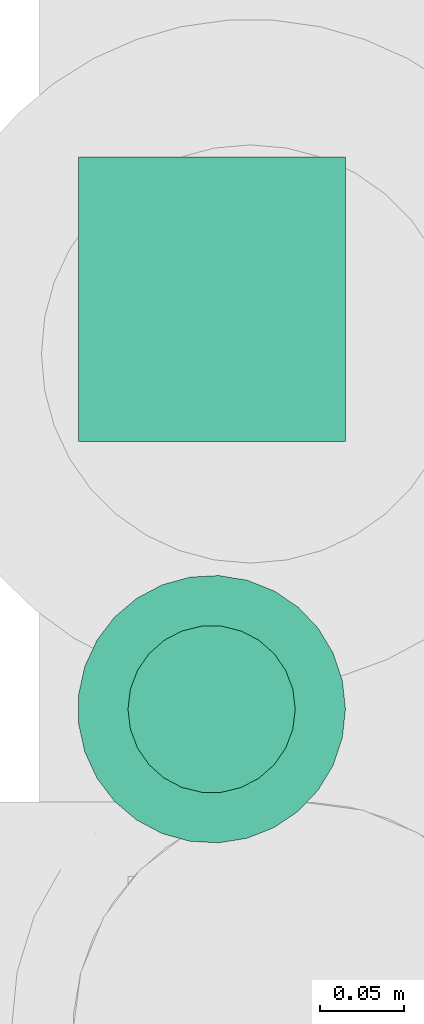
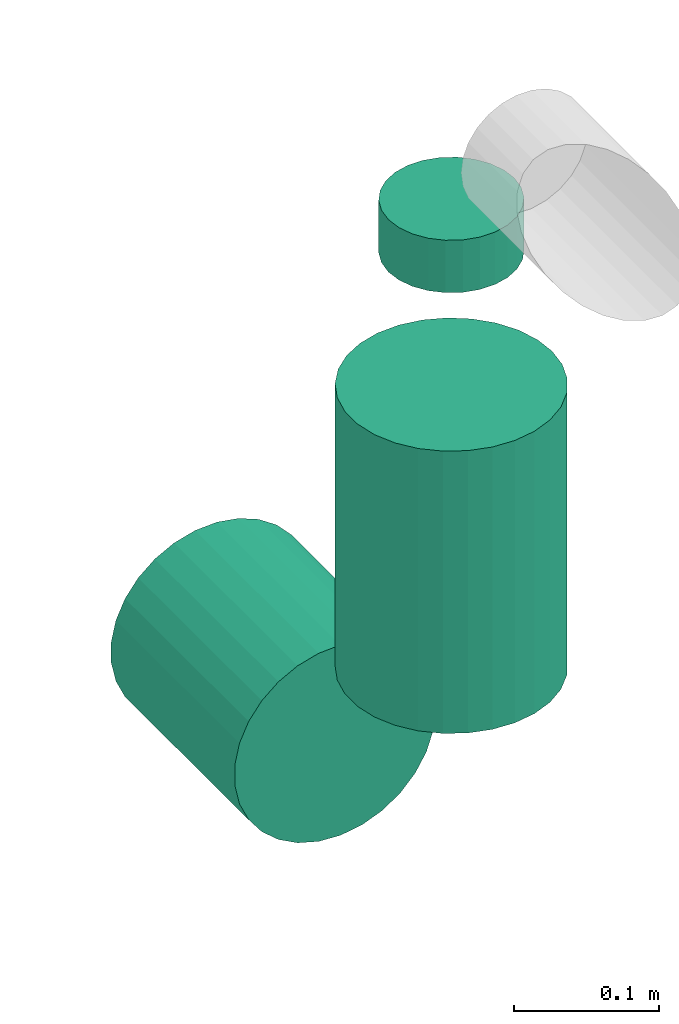
# One storey, part 307 of 337: 3 flow segments.
"""IFC2X3 building model written with IfcOpenShell, lengths in millimetres."""

from ifc_helpers import new_model, entity, si_unit, converted_unit, derived_unit, direction, frame, origin, origin_2d_with_axis, place, context, subcontext, project, spatial, circle, extrude, type_object, element, save


model = new_model("IFC2X3")

# Units and contexts
model_context = context("Model", 3, precision=0.01, world=origin(), true_north=direction((6.12303176911189e-17, 1.0)))
body_context = subcontext(model_context, "Body", "Model", "MODEL_VIEW")
ifc_project = project(units=[si_unit("LENGTHUNIT", "METRE", prefix="MILLI"), si_unit("AREAUNIT", "SQUARE_METRE"), si_unit("VOLUMEUNIT", "CUBIC_METRE"), converted_unit("PLANEANGLEUNIT", "DEGREE", entity("IfcRatioMeasure", 0.0174532925199433), si_unit("PLANEANGLEUNIT", "RADIAN"), dimensions=[0, 0, 0, 0, 0, 0, 0]), si_unit("MASSUNIT", "GRAM", prefix="KILO"), derived_unit("MASSDENSITYUNIT", [(si_unit("MASSUNIT", "GRAM", prefix="KILO"), 1), (si_unit("LENGTHUNIT", "METRE"), -3)]), derived_unit("MOMENTOFINERTIAUNIT", [(si_unit("LENGTHUNIT", "METRE"), 4)]), si_unit("TIMEUNIT", "SECOND"), si_unit("FREQUENCYUNIT", "HERTZ"), si_unit("THERMODYNAMICTEMPERATUREUNIT", "DEGREE_CELSIUS"), derived_unit("THERMALTRANSMITTANCEUNIT", [(si_unit("MASSUNIT", "GRAM", prefix="KILO"), 1), (si_unit("THERMODYNAMICTEMPERATUREUNIT", "KELVIN"), -1), (si_unit("TIMEUNIT", "SECOND"), -3)]), derived_unit("VOLUMETRICFLOWRATEUNIT", [(si_unit("LENGTHUNIT", "METRE"), 3), (si_unit("TIMEUNIT", "SECOND"), -1)]), derived_unit("MASSFLOWRATEUNIT", [(si_unit("MASSUNIT", "GRAM", prefix="KILO"), 1), (si_unit("TIMEUNIT", "SECOND"), -1)]), derived_unit("ROTATIONALFREQUENCYUNIT", [(si_unit("TIMEUNIT", "SECOND"), -1)]), si_unit("ELECTRICCURRENTUNIT", "AMPERE"), si_unit("ELECTRICVOLTAGEUNIT", "VOLT"), si_unit("POWERUNIT", "WATT"), si_unit("FORCEUNIT", "NEWTON", prefix="KILO"), si_unit("ILLUMINANCEUNIT", "LUX"), si_unit("LUMINOUSFLUXUNIT", "LUMEN"), si_unit("LUMINOUSINTENSITYUNIT", "CANDELA"), derived_unit("USERDEFINED", [(si_unit("MASSUNIT", "GRAM", prefix="KILO"), -1), (si_unit("LENGTHUNIT", "METRE"), -2), (si_unit("TIMEUNIT", "SECOND"), 3), (si_unit("LUMINOUSFLUXUNIT", "LUMEN"), 1)]), derived_unit("LINEARVELOCITYUNIT", [(si_unit("LENGTHUNIT", "METRE"), 1), (si_unit("TIMEUNIT", "SECOND"), -1)]), si_unit("PRESSUREUNIT", "PASCAL"), derived_unit("USERDEFINED", [(si_unit("LENGTHUNIT", "METRE"), -2), (si_unit("MASSUNIT", "GRAM", prefix="KILO"), 1), (si_unit("TIMEUNIT", "SECOND"), -2)]), derived_unit("LINEARFORCEUNIT", [(si_unit("MASSUNIT", "GRAM", prefix="KILO"), 1), (si_unit("LENGTHUNIT", "METRE"), 1), (si_unit("TIMEUNIT", "SECOND"), -2), (si_unit("LENGTHUNIT", "METRE"), -1)]), derived_unit("PLANARFORCEUNIT", [(si_unit("MASSUNIT", "GRAM", prefix="KILO"), 1), (si_unit("LENGTHUNIT", "METRE"), 1), (si_unit("TIMEUNIT", "SECOND"), -2), (si_unit("LENGTHUNIT", "METRE"), -2)])], contexts=[model_context])

# Site, building, storey
site_placement = place(None, origin())
site = spatial("IfcSite", under=ifc_project, at=site_placement, CompositionType="ELEMENT")
building_placement = place(site_placement, origin())
building = spatial("IfcBuilding", under=site, at=building_placement, CompositionType="ELEMENT")
storey_placement = place(building_placement, origin())
storey = spatial("IfcBuildingStorey", under=building, at=storey_placement, CompositionType="ELEMENT", Elevation=0.0)

# Flow segments
duct_segment_type = type_object("IfcDuctSegmentType", PredefinedType="NOTDEFINED")
flow_segment_1_placement = place(storey_placement, frame((72606.92, 10966.65, -1493.0)))
element("IfcFlowSegment", 1, at=flow_segment_1_placement, inside=storey, type_object=duct_segment_type, context=body_context, shape_type="SweptSolid", body=[
    extrude(circle(Radius=80.0, at=origin_2d_with_axis()), frame((81.6, 81.6, 0.0)), (0.0, 0.0, 1.0), 237.008955754027),
])
flow_segment_2_placement = place(storey_placement, frame((72606.92, 11208.25, -1734.6)))
element("IfcFlowSegment", 2, at=flow_segment_2_placement, inside=storey, type_object=duct_segment_type, context=body_context, shape_type="SweptSolid", body=[
    extrude(circle(Radius=80.0, at=origin_2d_with_axis()), frame((81.6, 0.0, 81.6), z_axis=(0.0, 1.0, 0.0), x_axis=(1.0, 0.0, 0.0)), (0.0, 0.0, 1.0), 170.000000000009),
])
flow_segment_3_placement = place(storey_placement, frame((72636.92, 10996.65, -1143.99)))
element("IfcFlowSegment", 3, at=flow_segment_3_placement, inside=storey, type_object=duct_segment_type, context=body_context, shape_type="SweptSolid", body=[
    extrude(circle(Radius=50.0, at=origin_2d_with_axis()), frame((51.6, 51.6, 0.0), z_axis=(0.0, 0.0, 1.0), x_axis=(-1.0, 0.0, 0.0)), (0.0, 0.0, 1.0), 43.9910442459797),
])

save(model, "model.ifc")
